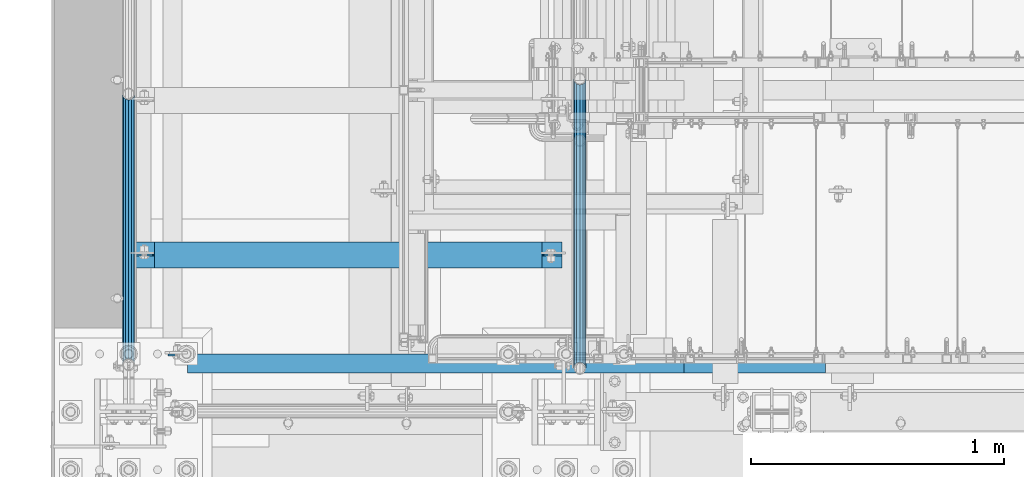
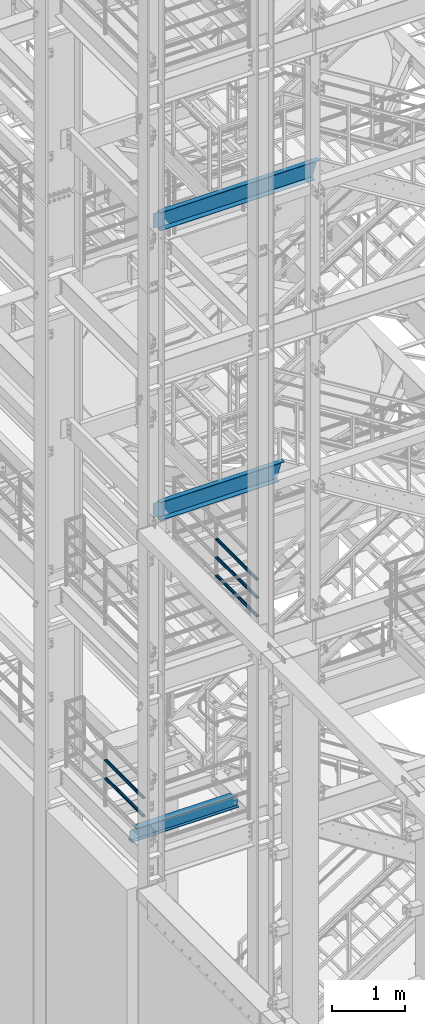
# One storey, part 934 of 1876: 8 beams, 5 elements without a shape of their own.
"""IFC2X3 building model written with IfcOpenShell, lengths in millimetres."""

from ifc_helpers import new_model, si_unit, frame, origin_with_axes, place, context, subcontext, project, spatial, faceted_brep, material, type_object, element, aggregate, save


model = new_model("IFC2X3")

# Units and contexts
model_context = context("Model", 3, precision=1e-05, world=origin_with_axes())
body_context = subcontext(model_context, "Body", "Model", "MODEL_VIEW")
ifc_project = project(units=[si_unit("LENGTHUNIT", "METRE", prefix="MILLI"), si_unit("AREAUNIT", "SQUARE_METRE"), si_unit("VOLUMEUNIT", "CUBIC_METRE"), si_unit("MASSUNIT", "GRAM", prefix="KILO"), si_unit("TIMEUNIT", "SECOND"), si_unit("PLANEANGLEUNIT", "RADIAN"), si_unit("SOLIDANGLEUNIT", "STERADIAN"), si_unit("THERMODYNAMICTEMPERATUREUNIT", "DEGREE_CELSIUS"), si_unit("LUMINOUSINTENSITYUNIT", "LUMEN")], contexts=[model_context])

# Site, building, storey
site_placement = place(None, origin_with_axes())
site = spatial("IfcSite", under=ifc_project, at=site_placement, CompositionType="ELEMENT")
building_placement = place(site_placement, origin_with_axes())
building = spatial("IfcBuilding", under=site, at=building_placement, Name="Undefined", CompositionType="ELEMENT")
storey_placement = place(building_placement, origin_with_axes())
storey = spatial("IfcBuildingStorey", under=building, at=storey_placement, Name="Undefined", CompositionType="ELEMENT", Elevation=0.0)

# Assembly, beam
assembly_1_placement = place(storey_placement, origin_with_axes())
assembly_1 = element("IfcElementAssembly", 1, at=assembly_1_placement, inside=storey, Name="BEAM", AssemblyPlace="NOTDEFINED", PredefinedType="RIGID_FRAME")
ifc_material_1 = material(Name="STEEL/A992")
beam_type_1 = type_object("IfcBeamType", Name="W8X15", PredefinedType="NOTDEFINED")
beam_1_placement = place(assembly_1_placement, frame((0.0, -6492.875, 5027.6125), z_axis=(0.0, 0.0, 1.0), x_axis=(1.0, 0.0, 0.0)))
beam_1 = element("IfcBeam", 2, at=beam_1_placement, type_object=beam_type_1, material=ifc_material_1, Name="BEAM", ObjectType="W8X15", context=body_context, shape_type="Brep", body=[
    faceted_brep([(1631.95, -50.8000000000002, 103.1875), (1631.95, -50.8000000000002, 95.25), (1631.95, -3.17500000000018, 95.25), (1631.95, -3.17500000000018, 87.3124998092653), (1631.95, 3.17500000000018, 87.3124998092653), (1631.95, 3.17500000000018, 95.25), (1631.95, 50.8000000000002, 95.25), (1631.95, 50.8000000000002, 103.1875), (1632.91672992259, -3.17500000000018, 82.4524202912198), (1632.91672992259, 3.17500000000018, 82.4524202912198), (1635.66974382307, -3.17500000000018, 78.3322438230662), (1635.66974382307, 3.17500000000018, 78.3322438230662), (1639.78992029122, -3.17500000000018, 75.5792299225877), (1639.78992029122, 3.17500000000018, 75.5792299225877), (1644.64999980926, -3.17500000000018, 74.6125000000002), (1644.64999980926, 3.17500000000018, 74.6125000000002), (1711.325, -3.17500000000018, 74.6125000000002), (1711.325, 3.17500000000018, 74.6125000000002), (101.599996948242, -50.8000000000002, 103.1875), (101.599996948242, 50.8000000000002, 103.1875), (101.599996948242, 50.8000000000002, 95.25), (101.599996948242, 3.17500000000018, 95.25), (101.599996948242, 3.17500000000018, 84.137499809267), (101.599996948242, -3.17500000000018, 84.137499809267), (101.599996948242, -3.17500000000018, 95.25), (101.599996948242, -50.8000000000002, 95.25), (100.633267025654, 3.17500000000018, 79.2774202912215), (100.633267025654, -3.17500000000018, 79.2774202912215), (97.8802531251764, 3.17500000000018, 75.1572438230678), (97.8802531251764, -3.17500000000018, 75.1572438230678), (93.7600766570227, 3.17500000000018, 72.4042299225894), (93.7600766570227, -3.17500000000018, 72.4042299225894), (88.8999971389772, 3.17500000000018, 71.4375000000018), (88.8999971389772, -3.17500000000018, 71.4375000000018), (17.4624999999998, 3.17500000000018, 71.4375000000018), (17.4624999999998, -3.17500000000018, 71.4375000000018), (17.4624999999998, 3.17500000000018, -95.25), (17.4624999999998, 50.8000000000002, -95.25), (17.4624999999998, 50.8000000000002, -103.1875), (17.4624999999998, -50.8000000000002, -103.1875), (17.4624999999998, -50.8000000000002, -95.25), (17.4624999999998, -3.17500000000018, -95.25), (1711.325, 3.17500000000018, -95.25), (1711.325, 50.8000000000002, -95.25), (1711.325, 50.8000000000002, -103.1875), (1711.325, -50.8000000000002, -103.1875), (1711.325, -50.8000000000002, -95.25), (1711.325, -3.17500000000018, -95.25)], [[[0, 1, 2, 3, 4, 5, 6, 7]], [[8, 9, 4, 3]], [[10, 11, 9, 8]], [[12, 13, 11, 10]], [[14, 15, 13, 12]], [[16, 17, 15, 14]], [[18, 19, 20, 21, 22, 23, 24, 25]], [[23, 22, 26, 27]], [[27, 26, 28, 29]], [[29, 28, 30, 31]], [[31, 30, 32, 33]], [[33, 32, 34, 35]], [[36, 37, 38, 39, 40, 41, 35, 34]], [[37, 36, 42, 43]], [[38, 37, 43, 44]], [[39, 38, 44, 45]], [[40, 39, 45, 46]], [[41, 40, 46, 47]], [[27, 29, 31, 33, 35, 41, 47, 16, 14, 12, 10, 8, 3, 2, 24, 23]], [[2, 1, 25, 24]], [[1, 0, 18, 25]], [[0, 7, 19, 18]], [[7, 6, 20, 19]], [[6, 5, 21, 20]], [[5, 4, 9, 11, 13, 15, 17, 42, 36, 34, 32, 30, 28, 26, 22, 21]], [[47, 46, 45, 44, 43, 42, 17, 16]]]),
])
aggregate(assembly_1, [beam_1])

# Assembly, beams
assembly_2_placement = place(storey_placement, origin_with_axes())
assembly_2 = element("IfcElementAssembly", 3, at=assembly_2_placement, inside=storey, Name="RAIL", AssemblyPlace="NOTDEFINED", PredefinedType="RIGID_FRAME")
ifc_material_2 = material()
beam_type_2 = type_object("IfcBeamType", Name="PIPE1-1/2SCH40", PredefinedType="NOTDEFINED")
beam_2_placement = place(assembly_2_placement, frame((1781.1750000007, -5797.55000057274, 8315.325), z_axis=(0.0, 0.0, 1.0), x_axis=(0.0, -1.0, 0.0)))
beam_2 = element("IfcBeam", 4, at=beam_2_placement, type_object=beam_type_2, material=ifc_material_2, Name="RAIL", ObjectType="PIPE1-1/2SCH40", context=body_context, shape_type="Brep", body=[
    faceted_brep([(1122.10280643392, -12.0650000000001, 20.8971929933177), (1122.10280643392, -12.0650000010112, 15.8661214301701), (1121.60937799578, -10.2235000000001, 17.7076214311801), (1118.86999942724, -2.11457518162206e-11, 20.4470000000001), (1118.86999942724, -2.11457518162206e-11, 24.1299999999992), (1121.60937799633, 10.2235000000001, 17.7076214311801), (1122.10280643392, 12.0649999989889, 15.866121432191), (1122.10280643392, 12.0650000000001, 20.8971929933177), (1142.99999942723, 24.1300000000001, 0.0), (1130.93499942724, 20.8971929933184, 12.0650000000005), (1130.93499942724, 20.8971929933184, -12.0650000000005), (1127.74542786611, 17.7076214311803, 10.2235000000001), (1130.48480643493, 20.4469999999999, 0.0), (1127.74542786611, 17.7076214311803, -10.2235000000001), (1122.10280643392, 12.0649999989889, -15.866121432191), (1122.10280643392, 12.0650000000001, -20.8971929933177), (1121.60937799633, 10.2235000000001, -17.7076214311801), (1118.86999942724, 0.0, -20.4470000000001), (1118.86999942724, 0.0, -24.1299999999992), (1122.10280643392, -12.0650000010112, -15.8661214301701), (1122.10280643392, -12.0650000000001, -20.8971929933177), (1121.60937799578, -10.2235000000001, -17.7076214311801), (1142.99999942724, -24.1300000010112, 0.0), (1130.93499942724, -20.8971929933184, -12.0650000000005), (1130.93499942724, -20.8971929933184, 12.0650000000005), (1127.74542786409, -17.7076214311803, -10.2235000000001), (1130.48480643291, -20.4469999999999, 0.0), (1127.74542786409, -17.7076214311803, 10.2235000000001), (12.0650000000064, -20.8971929933177, -12.0649999999987), (20.8971929933249, -12.0650000000005, -20.8971929933177), (0.0, 24.1299999999992, 0.0), (12.0650000000064, 20.8971929933177, -12.0649999999987), (12.0650000000064, 20.8971929933177, 12.0649999999987), (20.8971929933249, 12.0650000000005, 20.8971929933177), (24.1300000000064, 0.0, 24.130000000001), (20.8971929933249, 12.0650000000005, -20.8971929933177), (24.1300000000063, 0.0, -24.130000000001), (24.1300000000063, 0.0, -20.4470000000001), (20.8971929933249, -12.0650000000005, -15.8661214311796), (21.3906214311868, -10.2235000000001, -17.7076214311819), (21.3906214311868, 10.2235000000001, -17.7076214311819), (20.8971929933249, 12.0650000000005, -15.8661214311796), (15.2545715621445, 17.7076214311801, -10.2235000000001), (12.5151929933249, 20.4470000000001, 0.0), (15.2545715621445, 17.7076214311801, 10.2235000000001), (20.8971929933249, 12.0650000000005, 15.8661214311796), (21.3906214311868, 10.2235000000001, 17.7076214311819), (24.1300000000064, 0.0, 20.4470000000001), (21.3906214311868, -10.2235000000001, 17.7076214311819), (20.8971929933249, -12.0650000000005, 15.8661214311796), (20.8971929933249, -12.0650000000005, 20.8971929933177), (12.0650000000064, -20.8971929933177, 12.0649999999987), (0.0, -24.1299999999992, 0.0), (15.2545715621445, -17.7076214311801, 10.2235000000001), (12.5151929933249, -20.4470000000001, 0.0), (15.2545715621445, -17.7076214311801, -10.2235000000001)], [[[0, 1, 2, 3, 4]], [[4, 3, 5, 6, 7]], [[8, 9, 10]], [[7, 6, 11, 12, 13, 14, 15, 10, 9]], [[16, 17, 18, 15, 14]], [[19, 20, 18, 17, 21]], [[22, 23, 24]], [[24, 23, 20, 19, 25, 26, 27, 1, 0]], [[28, 29, 20, 23]], [[30, 31, 32]], [[33, 34, 4, 7]], [[32, 33, 7, 9]], [[30, 32, 9, 8]], [[31, 30, 8, 10]], [[35, 31, 10, 15]], [[36, 35, 15, 18]], [[29, 36, 18, 20]], [[37, 36, 29, 38, 39]], [[40, 41, 35, 36, 37]], [[32, 31, 35, 41, 42, 43, 44, 45, 33]], [[33, 45, 46, 47, 34]], [[34, 47, 48, 49, 50]], [[34, 50, 0, 4]], [[50, 51, 24, 0]], [[51, 52, 22, 24]], [[52, 28, 23, 22]], [[51, 28, 52]], [[50, 49, 53, 54, 55, 38, 29, 28, 51]], [[55, 54, 26, 25]], [[21, 39, 38, 55, 25, 19]], [[37, 39, 21, 17]], [[40, 37, 17, 16]], [[42, 41, 40, 16, 14, 13]], [[43, 42, 13, 12]], [[44, 43, 12, 11]], [[5, 46, 45, 44, 11, 6]], [[47, 46, 5, 3]], [[48, 47, 3, 2]], [[53, 49, 48, 2, 1, 27]], [[54, 53, 27, 26]]]),
])
beam_3_placement = place(assembly_2_placement, frame((1781.17499999997, -6940.55, 8620.125), z_axis=(0.0, 0.0, -1.0), x_axis=(0.0, 1.0, 0.0)))
beam_3 = element("IfcBeam", 5, at=beam_3_placement, type_object=beam_type_2, material=ifc_material_2, Name="RAIL", ObjectType="PIPE1-1/2SCH40", context=body_context, shape_type="Brep", body=[
    faceted_brep([(0.0, 24.1299999999992, 0.0), (12.0650000000064, 20.8971929933177, -12.0649999999987), (12.0650000000064, 20.8971929933177, 12.0649999999987), (12.0650000000064, -20.8971929933177, 12.0649999999987), (12.0650000000064, -20.8971929933177, -12.0649999999987), (0.0, -24.1299999999992, 0.0), (20.8971929933249, -12.0650000000005, 20.8971929933177), (20.8971929933249, -12.0650000000005, 15.8661214311796), (15.2545715621445, -17.7076214311801, 10.2235000000001), (12.5151929933249, -20.4470000000001, 0.0), (15.2545715621445, -17.7076214311801, -10.2235000000001), (20.8971929933249, -12.0650000000005, -15.8661214311796), (20.8971929933249, -12.0650000000005, -20.8971929933177), (24.1300000000063, 0.0, -20.4470000000001), (24.1300000000063, 0.0, -24.130000000001), (21.3906214311868, -10.2235000000001, -17.7076214311819), (21.3906214311868, 10.2235000000001, -17.7076214311819), (20.8971929933249, 12.0650000000005, -15.8661214311796), (20.8971929933249, 12.0650000000005, -20.8971929933177), (15.2545715621445, 17.7076214311801, -10.2235000000001), (12.5151929933249, 20.4470000000001, 0.0), (15.2545715621445, 17.7076214311801, 10.2235000000001), (20.8971929933249, 12.0650000000005, 15.8661214311796), (20.8971929933249, 12.0650000000005, 20.8971929933177), (21.3906214311868, 10.2235000000001, 17.7076214311819), (24.1300000000064, 0.0, 20.4470000000001), (24.1300000000064, 0.0, 24.130000000001), (21.3906214311868, -10.2235000000001, 17.7076214311819), (1142.99999942723, 24.1300000000001, 0.0), (1130.93499942724, 20.8971929933184, -12.0650000000005), (1122.10280643392, 12.0650000000001, -20.8971929933177), (1142.99999942724, -24.1300000010112, 0.0), (1130.93499942724, -20.8971929933184, -12.0650000000005), (1130.93499942724, -20.8971929933184, 12.0650000000005), (1122.10280643392, -12.0650000000001, 20.8971929933177), (1122.10280643392, -12.0650000000001, -20.8971929933177), (1118.86999942724, 0.0, -24.1299999999992), (1121.60937799633, 10.2235000000001, -17.7076214311801), (1118.86999942724, 0.0, -20.4470000000001), (1122.10280643392, 12.0649999989889, -15.866121432191), (1122.10280643392, -12.0650000010112, -15.8661214301701), (1121.60937799578, -10.2235000000001, -17.7076214311801), (1127.74542786409, -17.7076214311803, -10.2235000000001), (1130.48480643291, -20.4469999999999, 0.0), (1127.74542786409, -17.7076214311803, 10.2235000000001), (1122.10280643392, -12.0650000010112, 15.8661214301701), (1121.60937799578, -10.2235000000001, 17.7076214311801), (1118.86999942724, -2.11457518162206e-11, 20.4470000000001), (1118.86999942724, -2.11457518162206e-11, 24.1299999999992), (1122.10280643392, 12.0650000000001, 20.8971929933177), (1130.93499942724, 20.8971929933184, 12.0650000000005), (1122.10280643392, 12.0649999989889, 15.866121432191), (1127.74542786611, 17.7076214311803, 10.2235000000001), (1130.48480643493, 20.4469999999999, 0.0), (1127.74542786611, 17.7076214311803, -10.2235000000001), (1121.60937799633, 10.2235000000001, 17.7076214311801)], [[[0, 1, 2]], [[3, 4, 5]], [[6, 7, 8, 9, 10, 11, 12, 4, 3]], [[13, 14, 12, 11, 15]], [[16, 17, 18, 14, 13]], [[2, 1, 18, 17, 19, 20, 21, 22, 23]], [[23, 22, 24, 25, 26]], [[26, 25, 27, 7, 6]], [[1, 0, 28, 29]], [[18, 1, 29, 30]], [[31, 32, 33]], [[6, 3, 33, 34]], [[3, 5, 31, 33]], [[5, 4, 32, 31]], [[4, 12, 35, 32]], [[12, 14, 36, 35]], [[14, 18, 30, 36]], [[37, 38, 36, 30, 39]], [[40, 35, 36, 38, 41]], [[33, 32, 35, 40, 42, 43, 44, 45, 34]], [[34, 45, 46, 47, 48]], [[26, 6, 34, 48]], [[2, 23, 49, 50]], [[23, 26, 48, 49]], [[0, 2, 50, 28]], [[28, 50, 29]], [[49, 51, 52, 53, 54, 39, 30, 29, 50]], [[48, 47, 55, 51, 49]], [[25, 24, 55, 47]], [[55, 24, 22, 21, 52, 51]], [[21, 20, 53, 52]], [[20, 19, 54, 53]], [[19, 17, 16, 37, 39, 54]], [[16, 13, 38, 37]], [[13, 15, 41, 38]], [[41, 15, 11, 10, 42, 40]], [[10, 9, 43, 42]], [[9, 8, 44, 43]], [[8, 7, 27, 46, 45, 44]], [[27, 25, 47, 46]]]),
])
beam_4_placement = place(assembly_2_placement, frame((1781.17499999997, -6940.55, 8924.925), z_axis=(0.0, 0.0, -1.0), x_axis=(0.0, 1.0, 0.0)))
beam_4 = element("IfcBeam", 6, at=beam_4_placement, type_object=beam_type_2, material=ifc_material_2, Name="RAIL", ObjectType="PIPE1-1/2SCH40", context=body_context, shape_type="Brep", body=[
    faceted_brep([(0.0, 24.1299999999992, 0.0), (12.0650000000064, 20.8971929933177, -12.0649999999987), (12.0650000000064, 20.8971929933177, 12.0649999999987), (12.0650000000064, -20.8971929933177, 12.0649999999987), (12.0650000000064, -20.8971929933177, -12.0649999999987), (0.0, -24.1299999999992, 0.0), (20.8971929933249, -12.0650000000005, 20.8971929933177), (20.8971929933249, -12.0650000000005, 15.8661214311796), (15.2545715621445, -17.7076214311801, 10.2235000000001), (12.5151929933249, -20.4470000000001, 0.0), (15.2545715621445, -17.7076214311801, -10.2235000000001), (20.8971929933249, -12.0650000000005, -15.8661214311796), (20.8971929933249, -12.0650000000005, -20.8971929933177), (24.1300000000063, 0.0, -20.4470000000001), (24.1300000000063, 0.0, -24.130000000001), (21.3906214311868, -10.2235000000001, -17.7076214311819), (21.3906214311868, 10.2235000000001, -17.7076214311819), (20.8971929933249, 12.0650000000005, -15.8661214311796), (20.8971929933249, 12.0650000000005, -20.8971929933177), (15.2545715621445, 17.7076214311801, -10.2235000000001), (12.5151929933249, 20.4470000000001, 0.0), (15.2545715621445, 17.7076214311801, 10.2235000000001), (20.8971929933249, 12.0650000000005, 15.8661214311796), (20.8971929933249, 12.0650000000005, 20.8971929933177), (21.3906214311868, 10.2235000000001, 17.7076214311819), (24.1300000000064, 0.0, 20.4470000000001), (24.1300000000064, 0.0, 24.130000000001), (21.3906214311868, -10.2235000000001, 17.7076214311819), (1142.99999942723, 24.1300000000001, 0.0), (1130.93499942724, 20.8971929933184, -12.0650000000005), (1122.10280643392, 12.0650000000001, -20.8971929933177), (1142.99999942724, -24.1300000010112, 0.0), (1130.93499942724, -20.8971929933184, -12.0650000000005), (1130.93499942724, -20.8971929933184, 12.0650000000005), (1122.10280643392, -12.0650000000001, 20.8971929933177), (1122.10280643392, -12.0650000000001, -20.8971929933177), (1118.86999942724, 0.0, -24.1299999999992), (1121.60937799633, 10.2235000000001, -17.7076214311801), (1118.86999942724, 0.0, -20.4470000000001), (1122.10280643392, 12.0649999989889, -15.866121432191), (1122.10280643392, -12.0650000010112, -15.8661214301701), (1121.60937799578, -10.2235000000001, -17.7076214311801), (1127.74542786409, -17.7076214311803, -10.2235000000001), (1130.48480643291, -20.4469999999999, 0.0), (1127.74542786409, -17.7076214311803, 10.2235000000001), (1122.10280643392, -12.0650000010112, 15.8661214301701), (1121.60937799578, -10.2235000000001, 17.7076214311801), (1118.86999942724, -2.11457518162206e-11, 20.4470000000001), (1118.86999942724, -2.11457518162206e-11, 24.1299999999992), (1122.10280643392, 12.0650000000001, 20.8971929933177), (1130.93499942724, 20.8971929933184, 12.0650000000005), (1122.10280643392, 12.0649999989889, 15.866121432191), (1127.74542786611, 17.7076214311803, 10.2235000000001), (1130.48480643493, 20.4469999999999, 0.0), (1127.74542786611, 17.7076214311803, -10.2235000000001), (1121.60937799633, 10.2235000000001, 17.7076214311801)], [[[0, 1, 2]], [[3, 4, 5]], [[6, 7, 8, 9, 10, 11, 12, 4, 3]], [[13, 14, 12, 11, 15]], [[16, 17, 18, 14, 13]], [[2, 1, 18, 17, 19, 20, 21, 22, 23]], [[23, 22, 24, 25, 26]], [[26, 25, 27, 7, 6]], [[1, 0, 28, 29]], [[18, 1, 29, 30]], [[31, 32, 33]], [[6, 3, 33, 34]], [[3, 5, 31, 33]], [[5, 4, 32, 31]], [[4, 12, 35, 32]], [[12, 14, 36, 35]], [[14, 18, 30, 36]], [[37, 38, 36, 30, 39]], [[40, 35, 36, 38, 41]], [[33, 32, 35, 40, 42, 43, 44, 45, 34]], [[34, 45, 46, 47, 48]], [[26, 6, 34, 48]], [[2, 23, 49, 50]], [[23, 26, 48, 49]], [[0, 2, 50, 28]], [[28, 50, 29]], [[49, 51, 52, 53, 54, 39, 30, 29, 50]], [[48, 47, 55, 51, 49]], [[25, 24, 55, 47]], [[55, 24, 22, 21, 52, 51]], [[21, 20, 53, 52]], [[20, 19, 54, 53]], [[19, 17, 16, 37, 39, 54]], [[16, 13, 38, 37]], [[13, 15, 41, 38]], [[41, 15, 11, 10, 42, 40]], [[10, 9, 43, 42]], [[9, 8, 44, 43]], [[8, 7, 27, 46, 45, 44]], [[27, 25, 47, 46]]]),
])
aggregate(assembly_2, [beam_2, beam_3, beam_4])

assembly_3_placement = place(storey_placement, origin_with_axes())
assembly_3 = element("IfcElementAssembly", 7, at=assembly_3_placement, inside=storey, Name="RAIL", AssemblyPlace="NOTDEFINED", PredefinedType="RIGID_FRAME")
beam_5_placement = place(assembly_3_placement, frame((2.63753463514149e-11, -6925.94499999999, 5597.52500212598), z_axis=(0.0, 0.0, -1.0), x_axis=(0.0, 1.0, 0.0)))
beam_5 = element("IfcBeam", 8, at=beam_5_placement, type_object=beam_type_2, material=ifc_material_2, Name="RAIL", ObjectType="PIPE1-1/2SCH40", context=body_context, shape_type="Brep", body=[
    faceted_brep([(0.0, 24.1299999999992, 0.0), (12.0650000000064, 20.8971929933177, -12.0649999999987), (12.0650000000064, 20.8971929933177, 12.0649999999987), (12.0650000000064, -20.8971929933177, 12.0649999999987), (12.0650000000064, -20.8971929933177, -12.0649999999987), (0.0, -24.1299999999992, 0.0), (20.8971929933249, -12.0650000000005, 20.8971929933177), (20.8971929933249, -12.0650000000005, 15.8661214311796), (15.2545715621445, -17.7076214311801, 10.2235000000001), (12.5151929933249, -20.4470000000001, 0.0), (15.2545715621445, -17.7076214311801, -10.2235000000001), (20.8971929933249, -12.0650000000005, -15.8661214311796), (20.8971929933249, -12.0650000000005, -20.8971929933177), (24.1300000000063, 0.0, -20.4470000000001), (24.1300000000063, 0.0, -24.130000000001), (21.3906214311868, -10.2235000000001, -17.7076214311819), (21.3906214311868, 10.2235000000001, -17.7076214311819), (20.8971929933249, 12.0650000000005, -15.8661214311796), (20.8971929933249, 12.0650000000005, -20.8971929933177), (15.2545715621445, 17.7076214311801, -10.2235000000001), (12.5151929933249, 20.4470000000001, 0.0), (15.2545715621445, 17.7076214311801, 10.2235000000001), (20.8971929933249, 12.0650000000005, 15.8661214311796), (20.8971929933249, 12.0650000000005, 20.8971929933177), (21.3906214311868, 10.2235000000001, 17.7076214311819), (24.1300000000064, 0.0, 20.4470000000001), (24.1300000000064, 0.0, 24.130000000001), (21.3906214311868, -10.2235000000001, 17.7076214311819), (1068.86375, 24.1300000000001, 0.0), (1056.79875, 20.8971929933186, -12.0649999999987), (1047.96655700668, 12.0649999999996, -20.8971929933177), (1068.86375, -24.1299999999792, 0.0), (1056.79875, -20.8971929933186, -12.0649999999987), (1056.79875, -20.8971929933186, 12.0649999999987), (1047.96655700668, -12.0649999999996, 20.8971929933177), (1047.96655700668, -12.0649999999996, -20.8971929933177), (1044.73375, 0.0, -24.130000000001), (1047.47312856881, 10.2235000000001, -17.7076214311819), (1044.73375, 0.0, -20.4470000000001), (1047.96655700668, 12.0650000000205, -15.8661214311578), (1047.96655700668, -12.0649999999787, -15.8661214312015), (1047.47312856882, -10.2235000000001, -17.7076214311819), (1053.60917843788, -17.7076214311801, -10.2235000000001), (1056.3485570067, -20.4470000000001, 0.0), (1053.60917843788, -17.7076214311801, 10.2235000000001), (1047.96655700668, -12.0649999999787, 15.8661214312015), (1047.47312856882, -10.2235000000001, 17.7076214311819), (1044.73375, 9.09494701772928e-13, 20.4470000000001), (1044.73375, 9.09494701772928e-13, 24.130000000001), (1047.96655700668, 12.0649999999996, 20.8971929933177), (1056.79875, 20.8971929933186, 12.0649999999987), (1047.96655700668, 12.0650000000205, 15.8661214311578), (1053.60917843784, 17.7076214311801, 10.2235000000001), (1056.34855700666, 20.4470000000001, 0.0), (1053.60917843784, 17.7076214311801, -10.2235000000001), (1047.47312856881, 10.2235000000001, 17.7076214311819)], [[[0, 1, 2]], [[3, 4, 5]], [[6, 7, 8, 9, 10, 11, 12, 4, 3]], [[13, 14, 12, 11, 15]], [[16, 17, 18, 14, 13]], [[2, 1, 18, 17, 19, 20, 21, 22, 23]], [[23, 22, 24, 25, 26]], [[26, 25, 27, 7, 6]], [[1, 0, 28, 29]], [[18, 1, 29, 30]], [[31, 32, 33]], [[6, 3, 33, 34]], [[3, 5, 31, 33]], [[5, 4, 32, 31]], [[4, 12, 35, 32]], [[12, 14, 36, 35]], [[14, 18, 30, 36]], [[37, 38, 36, 30, 39]], [[40, 35, 36, 38, 41]], [[33, 32, 35, 40, 42, 43, 44, 45, 34]], [[34, 45, 46, 47, 48]], [[26, 6, 34, 48]], [[2, 23, 49, 50]], [[23, 26, 48, 49]], [[0, 2, 50, 28]], [[28, 50, 29]], [[49, 51, 52, 53, 54, 39, 30, 29, 50]], [[48, 47, 55, 51, 49]], [[25, 24, 55, 47]], [[55, 24, 22, 21, 52, 51]], [[21, 20, 53, 52]], [[20, 19, 54, 53]], [[19, 17, 16, 37, 39, 54]], [[16, 13, 38, 37]], [[13, 15, 41, 38]], [[41, 15, 11, 10, 42, 40]], [[10, 9, 43, 42]], [[9, 8, 44, 43]], [[8, 7, 27, 46, 45, 44]], [[27, 25, 47, 46]]]),
])
beam_6_placement = place(assembly_3_placement, frame((2.63753463514149e-11, -6925.94499999999, 5902.32500212598), z_axis=(0.0, 0.0, -1.0), x_axis=(0.0, 1.0, 0.0)))
beam_6 = element("IfcBeam", 9, at=beam_6_placement, type_object=beam_type_2, material=ifc_material_2, Name="RAIL", ObjectType="PIPE1-1/2SCH40", context=body_context, shape_type="Brep", body=[
    faceted_brep([(0.0, 24.1299999999992, 0.0), (12.0650000000064, 20.8971929933177, -12.0649999999987), (12.0650000000064, 20.8971929933177, 12.0649999999987), (12.0650000000064, -20.8971929933177, 12.0649999999987), (12.0650000000064, -20.8971929933177, -12.0649999999987), (0.0, -24.1299999999992, 0.0), (20.8971929933249, -12.0650000000005, 20.8971929933177), (20.8971929933249, -12.0650000000005, 15.8661214311796), (15.2545715621445, -17.7076214311801, 10.2235000000001), (12.5151929933249, -20.4470000000001, 0.0), (15.2545715621445, -17.7076214311801, -10.2235000000001), (20.8971929933249, -12.0650000000005, -15.8661214311796), (20.8971929933249, -12.0650000000005, -20.8971929933177), (24.1300000000063, 0.0, -20.4470000000001), (24.1300000000063, 0.0, -24.130000000001), (21.3906214311868, -10.2235000000001, -17.7076214311819), (21.3906214311868, 10.2235000000001, -17.7076214311819), (20.8971929933249, 12.0650000000005, -15.8661214311796), (20.8971929933249, 12.0650000000005, -20.8971929933177), (15.2545715621445, 17.7076214311801, -10.2235000000001), (12.5151929933249, 20.4470000000001, 0.0), (15.2545715621445, 17.7076214311801, 10.2235000000001), (20.8971929933249, 12.0650000000005, 15.8661214311796), (20.8971929933249, 12.0650000000005, 20.8971929933177), (21.3906214311868, 10.2235000000001, 17.7076214311819), (24.1300000000064, 0.0, 20.4470000000001), (24.1300000000064, 0.0, 24.130000000001), (21.3906214311868, -10.2235000000001, 17.7076214311819), (1068.86375, 24.1300000000001, 0.0), (1056.79875, 20.8971929933186, -12.0649999999987), (1047.96655700668, 12.0649999999996, -20.8971929933177), (1068.86375, -24.1299999999792, 0.0), (1056.79875, -20.8971929933186, -12.0649999999987), (1056.79875, -20.8971929933186, 12.0649999999987), (1047.96655700668, -12.0649999999996, 20.8971929933177), (1047.96655700668, -12.0649999999996, -20.8971929933177), (1044.73375, 0.0, -24.130000000001), (1047.47312856881, 10.2235000000001, -17.7076214311819), (1044.73375, 0.0, -20.4470000000001), (1047.96655700668, 12.0650000000205, -15.8661214311578), (1047.96655700668, -12.0649999999787, -15.8661214312015), (1047.47312856882, -10.2235000000001, -17.7076214311819), (1053.60917843788, -17.7076214311801, -10.2235000000001), (1056.3485570067, -20.4470000000001, 0.0), (1053.60917843788, -17.7076214311801, 10.2235000000001), (1047.96655700668, -12.0649999999787, 15.8661214312015), (1047.47312856882, -10.2235000000001, 17.7076214311819), (1044.73375, 9.09494701772928e-13, 20.4470000000001), (1044.73375, 9.09494701772928e-13, 24.130000000001), (1047.96655700668, 12.0649999999996, 20.8971929933177), (1056.79875, 20.8971929933186, 12.0649999999987), (1047.96655700668, 12.0650000000205, 15.8661214311578), (1053.60917843784, 17.7076214311801, 10.2235000000001), (1056.34855700666, 20.4470000000001, 0.0), (1053.60917843784, 17.7076214311801, -10.2235000000001), (1047.47312856881, 10.2235000000001, 17.7076214311819)], [[[0, 1, 2]], [[3, 4, 5]], [[6, 7, 8, 9, 10, 11, 12, 4, 3]], [[13, 14, 12, 11, 15]], [[16, 17, 18, 14, 13]], [[2, 1, 18, 17, 19, 20, 21, 22, 23]], [[23, 22, 24, 25, 26]], [[26, 25, 27, 7, 6]], [[1, 0, 28, 29]], [[18, 1, 29, 30]], [[31, 32, 33]], [[6, 3, 33, 34]], [[3, 5, 31, 33]], [[5, 4, 32, 31]], [[4, 12, 35, 32]], [[12, 14, 36, 35]], [[14, 18, 30, 36]], [[37, 38, 36, 30, 39]], [[40, 35, 36, 38, 41]], [[33, 32, 35, 40, 42, 43, 44, 45, 34]], [[34, 45, 46, 47, 48]], [[26, 6, 34, 48]], [[2, 23, 49, 50]], [[23, 26, 48, 49]], [[0, 2, 50, 28]], [[28, 50, 29]], [[49, 51, 52, 53, 54, 39, 30, 29, 50]], [[48, 47, 55, 51, 49]], [[25, 24, 55, 47]], [[55, 24, 22, 21, 52, 51]], [[21, 20, 53, 52]], [[20, 19, 54, 53]], [[19, 17, 16, 37, 39, 54]], [[16, 13, 38, 37]], [[13, 15, 41, 38]], [[41, 15, 11, 10, 42, 40]], [[10, 9, 43, 42]], [[9, 8, 44, 43]], [[8, 7, 27, 46, 45, 44]], [[27, 25, 47, 46]]]),
])
aggregate(assembly_3, [beam_5, beam_6])

# Assembly, beam
assembly_4_placement = place(storey_placement, origin_with_axes())
assembly_4 = element("IfcElementAssembly", 10, at=assembly_4_placement, inside=storey, Name="STRINGER", AssemblyPlace="NOTDEFINED", PredefinedType="RIGID_FRAME")
ifc_material_3 = material(Name="STEEL/A36")
beam_type_3 = type_object("IfcBeamType", Name="C12X20.7", PredefinedType="NOTDEFINED")
beam_7_placement = place(assembly_4_placement, frame((825.500001404659, -6921.50000114949, 15442.3768518501), z_axis=(0.0, 0.0, 1.0), x_axis=(1.0, 0.0, 0.0)))
beam_7 = element("IfcBeam", 11, at=beam_7_placement, type_object=beam_type_3, material=ifc_material_3, Name="STRINGER", ObjectType="C12X20.7", context=body_context, shape_type="Brep", body=[
    faceted_brep([(-669.925001746912, 30.1625000000004, -120.65), (-669.925001746913, 38.1000000000004, -120.65), (-606.425001556177, 38.1000000000004, -120.65), (-606.425001556177, 30.1625000000004, -120.65), (-601.564922038131, 38.1000000000004, -121.616729922587), (-601.564922038131, 30.1625000000004, -121.616729922587), (-597.444745569978, 38.1000000000004, -124.369743823065), (-597.444745569978, 30.1625000000004, -124.369743823065), (-594.6917316695, 38.1000000000004, -128.489920291218), (-594.6917316695, 30.1625000000004, -128.489920291218), (-593.725001746912, 30.1625000000004, -133.349999809265), (-593.725001746912, 38.1000000000004, -133.349999809265), (-593.725001746912, 38.1000000000004, -152.4), (-593.725001746912, -38.1000000000004, -152.4), (-593.725001746912, -38.1000000000004, -146.04746), (-593.725001746911, 30.1625000000004, -134.6749275), (1923.12210982147, -38.1000000000004, 146.04746), (1924.93044390773, -38.1000000000004, 152.4), (-593.725001746912, -38.1000000000004, 152.4), (-593.725001746912, -38.1000000000004, 146.04746), (1924.93044390773, 38.1000000000004, 152.4), (-593.725001746912, 38.1000000000004, 152.4), (-606.425001556177, 30.1625000000004, 120.65), (-606.425001556177, 38.1000000000004, 120.65), (-669.925001746912, 38.1000000000004, 120.65), (-669.925001746912, 30.1625000000004, 120.65), (-601.564922038131, 30.1625000000004, 121.616729922587), (-601.564922038131, 38.1000000000004, 121.616729922587), (-597.444745569978, 30.1625000000004, 124.369743823065), (-597.444745569978, 38.1000000000004, 124.369743823065), (-594.6917316695, 30.1625000000004, 128.489920291218), (-594.6917316695, 38.1000000000004, 128.489920291218), (-593.725001746912, 30.1625000000004, 133.349999809265), (-593.725001746912, 38.1000000000004, 133.349999809265), (-593.725001746912, 30.1625000000004, 134.6749275), (1919.88476882609, 30.1625000000004, 134.6749275), (1843.210788981, 30.1625000000004, -134.6749275), (1839.97344798561, -38.1000000000004, -146.04746), (1838.16511389935, -38.1000000000004, -152.4), (1838.16511389935, 38.1000000000004, -152.4)], [[[0, 1, 2, 3]], [[3, 2, 4, 5]], [[5, 4, 6, 7]], [[7, 6, 8, 9]], [[10, 11, 12, 13, 14, 15]], [[9, 8, 11, 10]], [[16, 17, 18, 19]], [[17, 20, 21, 18]], [[22, 23, 24, 25]], [[26, 27, 23, 22]], [[28, 29, 27, 26]], [[30, 31, 29, 28]], [[32, 33, 31, 30]], [[18, 21, 33, 32, 34, 19]], [[35, 16, 19, 34]], [[17, 16, 35, 36, 37, 38, 39, 20]], [[37, 36, 15, 14]], [[38, 37, 14, 13]], [[39, 38, 13, 12]], [[6, 4, 2, 1, 24, 23, 27, 29, 31, 33, 21, 20, 39, 12, 11, 8]], [[25, 24, 1, 0]], [[36, 35, 34, 32, 30, 28, 26, 22, 25, 0, 3, 5, 7, 9, 10, 15]]]),
])
aggregate(assembly_4, [beam_7])

assembly_5_placement = place(storey_placement, origin_with_axes())
assembly_5 = element("IfcElementAssembly", 12, at=assembly_5_placement, inside=storey, Name="STRINGER", AssemblyPlace="NOTDEFINED", PredefinedType="RIGID_FRAME")
beam_8_placement = place(assembly_5_placement, frame((1066.80000129097, -6921.50000114148, 10614.0250009579), z_axis=(0.0, 0.0, 1.0), x_axis=(1.0, 0.0, 0.0)))
beam_8 = element("IfcBeam", 13, at=beam_8_placement, type_object=beam_type_3, material=ifc_material_3, Name="STRINGER", ObjectType="C12X20.7", context=body_context, shape_type="Brep", body=[
    faceted_brep([(-911.225001633226, 30.1625000000004, -120.65), (-911.225001633226, 38.1000000000004, -120.65), (-847.725001442492, 38.1000000000004, -120.65), (-847.725001442492, 30.1625000000004, -120.65), (-842.864921924446, 38.1000000000004, -121.616729922587), (-842.864921924446, 30.1625000000004, -121.616729922587), (-838.744745456292, 38.1000000000004, -124.369743823065), (-838.744745456292, 30.1625000000004, -124.369743823065), (-835.991731555814, 38.1000000000004, -128.489920291218), (-835.991731555814, 30.1625000000004, -128.489920291218), (-835.025001633226, 30.1625000000004, -133.349999809265), (-835.025001633226, 38.1000000000004, -133.349999809265), (-835.025001633226, 38.1000000000004, -152.4), (-835.025001633226, -38.1000000000004, -152.4), (-835.025001633226, -38.1000000000004, -146.04746), (-835.025001633226, 30.1625000000004, -134.6749275), (1122.98949546434, -38.1000000000004, 146.04746), (1124.78695221114, -38.1000000000004, 152.4), (-835.025001633226, -38.1000000000004, 152.4), (-835.025001633226, -38.1000000000004, 146.04746), (1124.78695221114, 38.1000000000004, 152.4), (-835.025001633226, 38.1000000000004, 152.4), (-847.725001442492, 30.1625000000004, 120.65), (-847.725001442492, 38.1000000000004, 120.65), (-911.225001633226, 38.1000000000004, 120.65), (-911.225001633226, 30.1625000000004, 120.65), (-842.864921924446, 30.1625000000004, 121.616729922587), (-842.864921924446, 38.1000000000004, 121.616729922587), (-838.744745456292, 30.1625000000004, 124.369743823065), (-838.744745456292, 38.1000000000004, 124.369743823065), (-835.991731555814, 30.1625000000004, 128.489920291218), (-835.991731555814, 38.1000000000004, 128.489920291218), (-835.025001633226, 30.1625000000004, 133.349999809265), (-835.025001633226, 38.1000000000004, 133.349999809265), (-835.025001633226, 30.1625000000004, 134.6749275), (1119.77162745085, 30.1625000000004, 134.6749275), (1043.55885049537, 30.1625000000004, -134.6749275), (1040.34098248188, -38.1000000000004, -146.04746), (1038.54352573508, -38.1000000000004, -152.4), (1038.54352573508, 38.1000000000004, -152.4)], [[[0, 1, 2, 3]], [[3, 2, 4, 5]], [[5, 4, 6, 7]], [[7, 6, 8, 9]], [[10, 11, 12, 13, 14, 15]], [[9, 8, 11, 10]], [[16, 17, 18, 19]], [[17, 20, 21, 18]], [[22, 23, 24, 25]], [[26, 27, 23, 22]], [[28, 29, 27, 26]], [[30, 31, 29, 28]], [[32, 33, 31, 30]], [[18, 21, 33, 32, 34, 19]], [[35, 16, 19, 34]], [[17, 16, 35, 36, 37, 38, 39, 20]], [[37, 36, 15, 14]], [[38, 37, 14, 13]], [[39, 38, 13, 12]], [[6, 4, 2, 1, 24, 23, 27, 29, 31, 33, 21, 20, 39, 12, 11, 8]], [[25, 24, 1, 0]], [[36, 35, 34, 32, 30, 28, 26, 22, 25, 0, 3, 5, 7, 9, 10, 15]]]),
])
aggregate(assembly_5, [beam_8])

save(model, "model.ifc")
